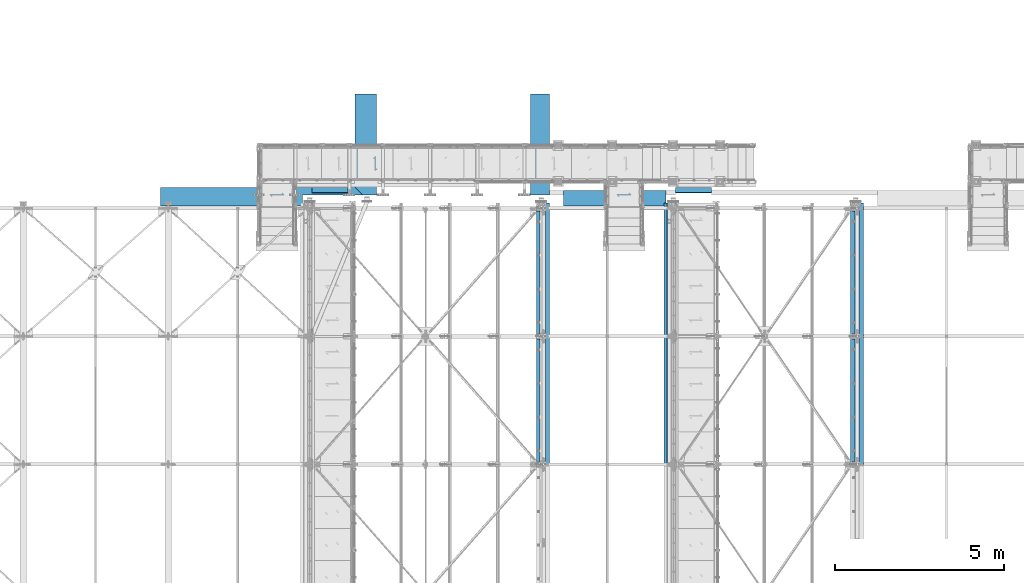
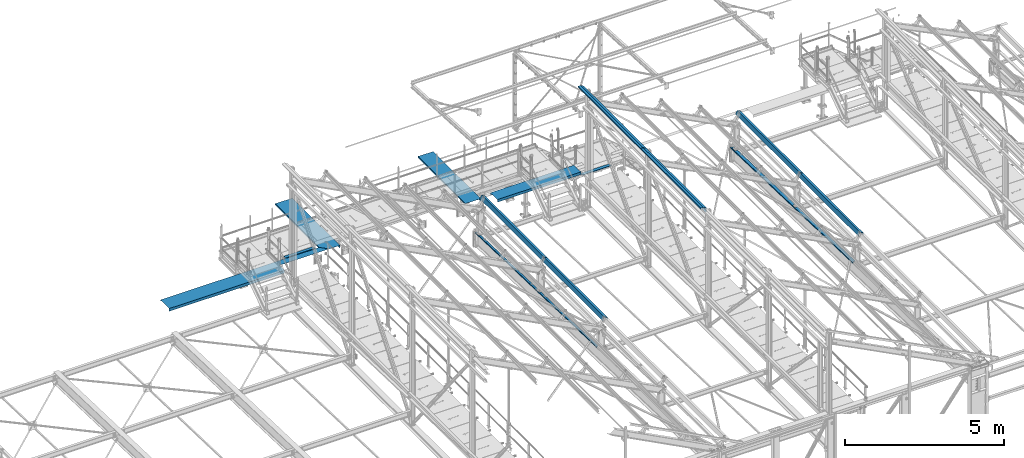
# One storey, part 349 of 496: 16 beams, 16 elements without a shape of their own.
"""IFC2X3 building model written with IfcOpenShell, lengths in millimetres."""

from ifc_helpers import new_model, si_unit, frame, origin_with_axes, place, context, subcontext, project, spatial, faceted_brep, material, type_object, element, aggregate, save


model = new_model("IFC2X3")

# Units and contexts
model_context = context("Model", 3, precision=1e-05, world=origin_with_axes())
body_context = subcontext(model_context, "Body", "Model", "MODEL_VIEW")
ifc_project = project(units=[si_unit("LENGTHUNIT", "METRE", prefix="MILLI"), si_unit("AREAUNIT", "SQUARE_METRE"), si_unit("VOLUMEUNIT", "CUBIC_METRE"), si_unit("MASSUNIT", "GRAM", prefix="KILO"), si_unit("TIMEUNIT", "SECOND"), si_unit("PLANEANGLEUNIT", "RADIAN"), si_unit("SOLIDANGLEUNIT", "STERADIAN"), si_unit("THERMODYNAMICTEMPERATUREUNIT", "DEGREE_CELSIUS"), si_unit("LUMINOUSINTENSITYUNIT", "LUMEN")], contexts=[model_context])

# Site, building, storey
site_placement = place(None, origin_with_axes())
site = spatial("IfcSite", under=ifc_project, at=site_placement, CompositionType="ELEMENT")
building_placement = place(site_placement, origin_with_axes())
building = spatial("IfcBuilding", under=site, at=building_placement, Name="Undefined", CompositionType="ELEMENT")
storey_placement = place(building_placement, origin_with_axes())
storey = spatial("IfcBuildingStorey", under=building, at=storey_placement, Name="Undefined", CompositionType="ELEMENT", Elevation=0.0)

# Assembly, beam
assembly_1_placement = place(storey_placement, origin_with_axes())
assembly_1 = element("IfcElementAssembly", 1, at=assembly_1_placement, inside=storey, AssemblyPlace="NOTDEFINED", PredefinedType="NOTDEFINED")
ifc_material = material(Name="Undefined/S235-E24")
beam_type_1 = type_object("IfcBeamType", PredefinedType="NOTDEFINED")
beam_1_placement = place(assembly_1_placement, frame((13279.0100000575, 15804.7464905488, 8669.96021550788), z_axis=(-1.0, 0.0, 0.0), x_axis=(0.0, 0.707106781186548, -0.707106781186548)))
beam_1 = element("IfcBeam", 2, at=beam_1_placement, type_object=beam_type_1, material=ifc_material, context=body_context, shape_type="Brep", body=[
    faceted_brep([(-9.09494701772928e-13, -0.5, -532.5), (-9.09494701772928e-13, -0.5, 532.5), (0.0, 0.5, 532.5), (0.0, 0.5, -532.5), (14.9999999961674, 0.5, 532.5), (14.9999999961674, 0.5, -532.5), (12.5857864337941, -0.5, -532.5), (12.5857864337941, -0.5, 532.5), (-20.3553390631714, -34.855339059337, 532.5), (-20.3553390631714, -34.855339059337, -532.5), (-20.4043516593701, -33.4901380931624, -532.5), (-20.4043516593701, -33.4901380931624, 532.5), (-136.320853875218, 65.5538265665964, 532.5), (-136.320853875218, 65.5538265665964, -532.5), (-136.369866471417, 66.919027532771, -532.5), (-136.369866471417, 66.919027532771, 532.5), (-150.462992196356, 51.4116882454582, 532.5), (-150.462992196356, 51.4116882454582, -532.5), (-151.170098977543, 52.1187950266467, 532.5), (-151.170098977543, 52.1187950266467, -532.5)], [[[0, 1, 2, 3]], [[3, 2, 4, 5]], [[1, 0, 6, 7]], [[5, 4, 8, 9]], [[7, 6, 10, 11]], [[9, 8, 12, 13]], [[11, 10, 14, 15]], [[13, 12, 16, 17]], [[12, 8, 4, 2, 1, 7, 11, 15, 18, 16]], [[15, 14, 19, 18]], [[14, 10, 6, 0, 3, 5, 9, 13, 17, 19]], [[18, 19, 17, 16]]]),
])
aggregate(assembly_1, [beam_1])

assembly_2_placement = place(storey_placement, origin_with_axes())
assembly_2 = element("IfcElementAssembly", 3, at=assembly_2_placement, inside=storey, AssemblyPlace="NOTDEFINED", PredefinedType="NOTDEFINED")
beam_2_placement = place(assembly_2_placement, frame((24069.0000000574, 15804.7467135916, 8079.96015603329), z_axis=(-1.0, 0.0, 0.0), x_axis=(0.0, 0.707106781186548, -0.707106781186548)))
beam_2 = element("IfcBeam", 4, at=beam_2_placement, type_object=beam_type_1, material=ifc_material, context=body_context, shape_type="Brep", body=[
    faceted_brep([(-9.09494701772928e-13, -0.5, -532.5), (-9.09494701772928e-13, -0.5, 532.5), (0.0, 0.5, 532.5), (0.0, 0.5, -532.5), (14.9999999961674, 0.5, 532.5), (14.9999999961674, 0.5, -532.5), (12.5857864337941, -0.5, -532.5), (12.5857864337941, -0.5, 532.5), (-20.3553390631714, -34.855339059337, 532.5), (-20.3553390631714, -34.855339059337, -532.5), (-20.4043516593701, -33.4901380931624, -532.5), (-20.4043516593701, -33.4901380931624, 532.5), (-136.320853875218, 65.5538265665964, 532.5), (-136.320853875218, 65.5538265665964, -532.5), (-136.369866471417, 66.919027532771, -532.5), (-136.369866471417, 66.919027532771, 532.5), (-150.462992196356, 51.4116882454582, 532.5), (-150.462992196356, 51.4116882454582, -532.5), (-151.170098977543, 52.1187950266467, 532.5), (-151.170098977543, 52.1187950266467, -532.5)], [[[0, 1, 2, 3]], [[3, 2, 4, 5]], [[1, 0, 6, 7]], [[5, 4, 8, 9]], [[7, 6, 10, 11]], [[9, 8, 12, 13]], [[11, 10, 14, 15]], [[13, 12, 16, 17]], [[12, 8, 4, 2, 1, 7, 11, 15, 18, 16]], [[15, 14, 19, 18]], [[14, 10, 6, 0, 3, 5, 9, 13, 17, 19]], [[18, 19, 17, 16]]]),
])
aggregate(assembly_2, [beam_2])

assembly_3_placement = place(storey_placement, origin_with_axes())
assembly_3 = element("IfcElementAssembly", 5, at=assembly_3_placement, inside=storey, AssemblyPlace="NOTDEFINED", PredefinedType="NOTDEFINED")
beam_type_2 = type_object("IfcBeamType", PredefinedType="NOTDEFINED")
beam_3_placement = place(assembly_3_placement, frame((19791.0707772034, 17089.9997612773, 8485.02993144951), z_axis=(0.0, 1.0, 0.0), x_axis=(-0.104503987949868, 0.0, 0.994524467523335)))
beam_3 = element("IfcBeam", 6, at=beam_3_placement, type_object=beam_type_2, material=ifc_material, context=body_context, shape_type="Brep", body=[
    faceted_brep([(6.45741238258779e-11, -0.500000000003638, -1500.0), (6.45741238258779e-11, -0.500000000003638, 1500.0), (-6.82121026329696e-11, 0.5, 1500.0), (-6.82121026329696e-11, 0.5, -1500.0), (14.9999488691874, 0.50000000199725, 1500.0), (14.9999488691874, 0.50000000199725, -1500.0), (15.0523282426693, -0.499999997999112, -1500.0), (15.0523282426693, -0.499999997999112, 1500.0), (104.50745235149, 9.90249056020184, 1500.0), (104.50745235149, 9.90249056020184, -1500.0), (103.635028489763, 8.80534279774656, -1500.0), (103.635028489763, 8.80534279774656, 1500.0), (172.974732576857, -545.986188069808, 1500.0), (172.974732576857, -545.986188069808, -1500.0), (171.857784889847, -545.098036786021, -1500.0), (171.857784889847, -545.098036786021, 1500.0), (123.250123489634, -551.210542755707, 1500.0), (123.250123489634, -551.210542755707, -1500.0), (125.546581443116, -549.963759356357, -1500.0), (125.546581443116, -549.963759356357, 1500.0), (132.690217238004, -539.553558699641, 1500.0), (132.690217238004, -539.553558699641, -1500.0), (133.467348390615, -540.18289737765, 1500.0), (133.467348390615, -540.18289737765, -1500.0)], [[[0, 1, 2, 3]], [[3, 2, 4, 5]], [[1, 0, 6, 7]], [[5, 4, 8, 9]], [[7, 6, 10, 11]], [[9, 8, 12, 13]], [[11, 10, 14, 15]], [[13, 12, 16, 17]], [[15, 14, 18, 19]], [[17, 16, 20, 21]], [[16, 12, 8, 4, 2, 1, 7, 11, 15, 19, 22, 20]], [[19, 18, 23, 22]], [[18, 14, 10, 6, 0, 3, 5, 9, 13, 17, 21, 23]], [[22, 23, 21, 20]]]),
])
aggregate(assembly_3, [beam_3])

assembly_4_placement = place(storey_placement, origin_with_axes())
assembly_4 = element("IfcElementAssembly", 7, at=assembly_4_placement, inside=storey, AssemblyPlace="NOTDEFINED", PredefinedType="NOTDEFINED")
beam_4_placement = place(assembly_4_placement, frame((14661.0707772034, 17089.9997612773, 8485.02993144951), z_axis=(0.0, 1.0, 0.0), x_axis=(-0.104503987949868, 0.0, 0.994524467523335)))
beam_4 = element("IfcBeam", 8, at=beam_4_placement, type_object=beam_type_2, material=ifc_material, context=body_context, shape_type="Brep", body=[
    faceted_brep([(-6.82121026329696e-11, 0.5, -1500.0), (-6.82121026329696e-11, 0.5, 1500.0), (14.9999488691874, 0.50000000199725, 1500.0), (14.9999488691874, 0.50000000199725, -1500.0), (6.45741238258779e-11, -0.500000000003638, -1500.0), (6.45741238258779e-11, -0.500000000003638, 1500.0), (15.0523282426693, -0.499999997999112, -1500.0), (15.0523282426693, -0.499999997999112, 1500.0), (103.633088593667, 8.80513901758604, -1500.0), (103.633088593667, 8.80513901758604, 1500.0), (130.5654026462, -620.827255485461, 1500.0), (180.29001173347, -615.602900799553, 1500.0), (104.50745235149, 9.90249056020184, 1500.0), (179.175070573579, -614.714538698441, 1500.0), (132.861860599676, -619.580472086111, 1500.0), (140.782627547223, -609.799610107335, 1500.0), (140.00549639461, -609.170271429324, 1500.0), (104.50745235149, 9.90249056020184, -1500.0), (153.224504095733, -392.205577123423, -1500.0), (152.229854354479, -392.31009427456, -1500.0), (179.175070573579, -614.714538698441, -1275.99735128642), (132.861860599676, -619.580472086111, -1275.99797658939), (140.782627547223, -609.799610107335, -1284.89753556321), (140.00549639461, -609.170271429324, -1285.60464191098), (130.5654026462, -620.827255485461, -1274.99800853966), (180.29001173347, -615.602900799553, -1274.99733717729)], [[[0, 1, 2, 3]], [[4, 5, 1, 0]], [[5, 4, 6, 7]], [[7, 6, 8, 9]], [[10, 11, 12, 2, 1, 5, 7, 9, 13, 14, 15, 16]], [[3, 2, 12, 17]], [[8, 6, 4, 0, 3, 17, 18, 19]], [[13, 9, 8, 19, 20]], [[14, 13, 20, 21]], [[15, 14, 21, 22]], [[16, 15, 22, 23]], [[10, 16, 23, 24]], [[11, 10, 24, 25]], [[17, 12, 11, 25, 18]], [[24, 23, 22, 21, 20, 19, 18, 25]]]),
])
aggregate(assembly_4, [beam_4])

assembly_5_placement = place(storey_placement, origin_with_axes())
assembly_5 = element("IfcElementAssembly", 9, at=assembly_5_placement, inside=storey, Name="SHED", AssemblyPlace="NOTDEFINED", PredefinedType="NOTDEFINED")
beam_type_3 = type_object("IfcBeamType", PredefinedType="NOTDEFINED")
beam_5_placement = place(assembly_5_placement, frame((28966.3687317403, 9500.00024422104, 8772.7482869049), z_axis=(0.0, 1.0, 0.0), x_axis=(-0.887870604061621, -1.29999898490562e-08, 0.460093241031915)))
beam_5 = element("IfcBeam", 10, at=beam_5_placement, type_object=beam_type_3, material=ifc_material, Name="SHED", context=body_context, shape_type="Brep", body=[
    faceted_brep([(-3.49427864421159e-08, -1.49999999999636, -1895.0), (-3.52956703864038e-08, -1.5, 1895.0), (3.49573383573443e-08, 1.5, 1895.0), (3.53102223016322e-08, 1.5, -1895.0), (47.0000011861484, 1.499998899395, 1895.0), (47.0000011898519, 1.49999889939863, -1895.0), (50.0000011927114, -1.50000117085074, -1895.0), (50.0000011890152, -1.50000117085438, 1895.0), (47.000001059947, 135.500002207569, 1895.00000000012), (47.0000010603762, 135.500002214732, -1894.99999999988), (50.0000010575095, 138.500002217588, -1894.99999999987), (50.0000010570839, 138.500002210421, 1895.00000000013), (-88.1757271770839, 135.5000020808, 1895.00000000025), (-88.1757271818278, 135.500002084245, -1894.99999999975), (-90.0000023299144, 138.50000208251, -1894.99999999975), (-90.0000023251705, 138.500002079061, 1895.00000000025), (-124.143850124739, 66.0900733967574, 1895.00000000026), (-124.143850129109, 66.0900733984818, -1894.99999999974), (-126.807461936929, 67.4703531198502, 1895.00000000026), (-126.807461941291, 67.4703531215746, -1894.99999999974)], [[[0, 1, 2, 3]], [[3, 2, 4, 5]], [[1, 0, 6, 7]], [[5, 4, 8, 9]], [[7, 6, 10, 11]], [[9, 8, 12, 13]], [[11, 10, 14, 15]], [[13, 12, 16, 17]], [[12, 8, 4, 2, 1, 7, 11, 15, 18, 16]], [[15, 14, 19, 18]], [[14, 10, 6, 0, 3, 5, 9, 13, 17, 19]], [[18, 19, 17, 16]]]),
])
aggregate(assembly_5, [beam_5])

assembly_6_placement = place(storey_placement, origin_with_axes())
assembly_6 = element("IfcElementAssembly", 11, at=assembly_6_placement, inside=storey, Name="SHED", AssemblyPlace="NOTDEFINED", PredefinedType="NOTDEFINED")
beam_6_placement = place(assembly_6_placement, frame((19656.0539262703, 9500.00010459345, 8773.41543701596), z_axis=(0.0, 1.0, 0.0), x_axis=(-0.886081824994261, -1.3000000762986e-08, 0.46352885499701)))
beam_6 = element("IfcBeam", 12, at=beam_6_placement, type_object=beam_type_3, material=ifc_material, Name="SHED", context=body_context, shape_type="Brep", body=[
    faceted_brep([(-3.49427864421159e-08, -1.49999999999636, -1895.0), (-3.52956703864038e-08, -1.5, 1895.0), (3.49573383573443e-08, 1.5, 1895.0), (3.53102223016322e-08, 1.5, -1895.0), (47.0000011861484, 1.499998899395, 1895.0), (47.0000011898519, 1.49999889939863, -1895.0), (50.0000011927114, -1.50000117085074, -1895.0), (50.0000011890152, -1.50000117085438, 1895.0), (47.000001059947, 135.500002207569, 1895.00000000012), (47.0000010603762, 135.500002214732, -1894.99999999988), (50.0000010575095, 138.500002217588, -1894.99999999987), (50.0000010570839, 138.500002210421, 1895.00000000013), (-88.1836776470482, 135.500002842484, 1895.0000000002), (-88.1836776506789, 135.500002845067, -1894.9999999998), (-90.0000023299144, 138.50000208251, -1894.99999999975), (-90.0000023251705, 138.500002079061, 1895.00000000025), (-124.424035514965, 66.2228546085316, 1895.00000000021), (-124.424035518201, 66.2228546098777, -1894.99999999979), (-127.082281608209, 67.6134399916555, 1895.00000000021), (-127.082281611441, 67.6134399930015, -1894.99999999979)], [[[0, 1, 2, 3]], [[3, 2, 4, 5]], [[1, 0, 6, 7]], [[5, 4, 8, 9]], [[7, 6, 10, 11]], [[9, 8, 12, 13]], [[11, 10, 14, 15]], [[13, 12, 16, 17]], [[12, 8, 4, 2, 1, 7, 11, 15, 18, 16]], [[15, 14, 19, 18]], [[14, 10, 6, 0, 3, 5, 9, 13, 17, 19]], [[18, 19, 17, 16]]]),
])
aggregate(assembly_6, [beam_6])

assembly_7_placement = place(storey_placement, origin_with_axes())
assembly_7 = element("IfcElementAssembly", 13, at=assembly_7_placement, inside=storey, Name="SHED", AssemblyPlace="NOTDEFINED", PredefinedType="NOTDEFINED")
beam_7_placement = place(assembly_7_placement, frame((23194.99999895, 9500.00015768597, 11825.822934215), z_axis=(0.0, 1.0, 0.0), x_axis=(0.0, 0.0, 1.0)))
beam_7 = element("IfcBeam", 14, at=beam_7_placement, type_object=beam_type_3, material=ifc_material, Name="SHED", context=body_context, shape_type="Brep", body=[
    faceted_brep([(-3.49427864421159e-08, -1.49999999999636, -1895.0), (-3.52956703864038e-08, -1.5, 1895.0), (3.49573383573443e-08, 1.5, 1895.0), (3.53102223016322e-08, 1.5, -1895.0), (47.0000011861484, 1.499998899395, 1895.0), (47.0000011898519, 1.49999889939863, -1895.0), (50.0000011927114, -1.50000117085074, -1895.0), (50.0000011890152, -1.50000117085438, 1895.0), (47.0, 83.4669820349482, 1895.0), (47.0, 83.4669820349482, -1895.0), (50.0, 84.198112487793, -1895.0), (50.0, 84.198112487793, 1895.0), (-16.2373286826551, 205.5, 1895.0), (-16.2373286826551, 205.5, -1895.0), (-14.4130535125732, 208.5, -1895.0), (-14.4130535125732, 208.5, 1895.0), (-151.413055419922, 205.5, 1895.0), (-151.413055419922, 205.5, -1895.0), (-154.413055419922, 208.5, -1895.0), (-154.413055419922, 208.5, 1895.0), (-151.413055419922, 158.5, 1895.0), (-151.413055419922, 158.5, -1895.0), (-154.413055419922, 158.5, 1895.0), (-154.413055419922, 158.5, -1895.0)], [[[0, 1, 2, 3]], [[3, 2, 4, 5]], [[1, 0, 6, 7]], [[5, 4, 8, 9]], [[7, 6, 10, 11]], [[9, 8, 12, 13]], [[11, 10, 14, 15]], [[13, 12, 16, 17]], [[15, 14, 18, 19]], [[17, 16, 20, 21]], [[16, 12, 8, 4, 2, 1, 7, 11, 15, 19, 22, 20]], [[19, 18, 23, 22]], [[18, 14, 10, 6, 0, 3, 5, 9, 13, 17, 21, 23]], [[22, 23, 21, 20]]]),
])
aggregate(assembly_7, [beam_7])

assembly_8_placement = place(storey_placement, origin_with_axes())
assembly_8 = element("IfcElementAssembly", 15, at=assembly_8_placement, inside=storey, AssemblyPlace="NOTDEFINED", PredefinedType="NOTDEFINED")
beam_type_4 = type_object("IfcBeamType", PredefinedType="NOTDEFINED")
beam_8_placement = place(assembly_8_placement, frame((21731.0000035513, 15725.551813145, 8490.0025537872), z_axis=(-1.0, 0.0, 0.0), x_axis=(0.0, -0.104503983004557, 0.994524468042986)))
beam_8 = element("IfcBeam", 16, at=beam_8_placement, type_object=beam_type_4, material=ifc_material, context=body_context, shape_type="Brep", body=[
    faceted_brep([(2.60934029938653e-09, -0.5, -1522.5), (2.60934029938653e-09, -0.5, 1522.5), (-2.6102497940883e-09, 0.5, 1522.5), (-2.6102497940883e-09, 0.5, -1522.5), (9.99994928593878, 0.500000052190444, 1522.5), (9.99994928593878, 0.500000052190444, -1522.5), (10.0523286619564, -0.499999947536708, -1522.5), (10.0523286619564, -0.499999947536708, 1522.5), (99.5074489744575, 9.90249021175259, 1522.5), (99.5074489744575, 9.90249021175259, -1522.5), (98.6392763577842, 8.8057890296368, -1522.5), (98.6392763577842, 8.8057890296368, 1522.5), (156.478023181317, -436.588628127614, 1522.5), (156.478023181317, -436.588628127614, -1522.5), (155.356650238834, -435.700941786734, -1522.5), (155.356650238834, -435.700941786734, 1522.5), (57.0288088006118, -447.037337100774, 1522.5), (57.0288088006118, -447.037337100774, -1522.5), (59.3252667540892, -445.790553701425, -1522.5), (59.3252667540892, -445.790553701425, 1522.5), (66.4689025490106, -435.380353044651, 1522.5), (66.4689025490106, -435.380353044651, -1522.5), (67.2460337016237, -436.009691722662, 1522.5), (67.2460337016237, -436.009691722662, -1522.5)], [[[0, 1, 2, 3]], [[3, 2, 4, 5]], [[1, 0, 6, 7]], [[5, 4, 8, 9]], [[7, 6, 10, 11]], [[9, 8, 12, 13]], [[11, 10, 14, 15]], [[13, 12, 16, 17]], [[15, 14, 18, 19]], [[17, 16, 20, 21]], [[16, 12, 8, 4, 2, 1, 7, 11, 15, 19, 22, 20]], [[19, 18, 23, 22]], [[18, 14, 10, 6, 0, 3, 5, 9, 13, 17, 21, 23]], [[22, 23, 21, 20]]]),
])
aggregate(assembly_8, [beam_8])

assembly_9_placement = place(storey_placement, origin_with_axes())
assembly_9 = element("IfcElementAssembly", 17, at=assembly_9_placement, inside=storey, AssemblyPlace="NOTDEFINED", PredefinedType="NOTDEFINED")
beam_type_5 = type_object("IfcBeamType", PredefinedType="NOTDEFINED")
beam_9_placement = place(assembly_9_placement, frame((11255.0000220992, 15273.9292663484, 8485.02993144988), z_axis=(-1.0, 0.0, 0.0), x_axis=(0.0, 0.104503986960844, 0.994524467627261)))
beam_9 = element("IfcBeam", 18, at=beam_9_placement, type_object=beam_type_5, material=ifc_material, context=body_context, shape_type="Brep", body=[
    faceted_brep([(104.507452360738, -9.90249045622295, -1208.49998630155), (14.9999488691446, -0.499999987074261, -1208.49998630155), (4.29281499236822e-10, -0.5, -1208.49998630155), (-4.3473846744746e-10, 0.499999999998181, -1208.49998630155), (15.0523282416307, 0.500000012969394, -1208.49998630155), (103.635672343446, -8.80541032864312, -1208.49998630155), (142.231865183261, 302.865200793538, -1208.49998630155), (143.226560122237, 302.760678893559, -1208.49998630155), (143.226559864101, 302.760678920684, -2999.99998630155), (142.231863460132, 302.865186878984, -3000.0), (169.765982206049, 525.207728586827, 3000.0), (123.455446477181, 530.073380956279, 3000.0), (123.455446477181, 530.073380956279, -2775.99820668076), (169.765982206049, 525.207728586827, -2775.99758141508), (131.376213434367, 520.292518985494, 3000.0), (131.376213434367, 520.292518985494, -2784.89775735025), (130.599082282382, 519.66318030671, 3000.0), (121.158988522466, 531.320164353345, 3000.0), (121.158988522466, 531.320164353345, -2774.99823956407), (130.599082282382, 519.66318030671, -2785.60486303819), (103.635672343446, -8.80541032864312, 3000.0), (15.0523282416307, 0.500000012969394, 3000.0), (-4.3473846744746e-10, 0.499999999998181, 3000.0), (4.29281499236822e-10, -0.5, 3000.0), (14.9999488691446, -0.499999987074261, 3000.0), (104.507452360738, -9.90249045622295, 3000.0), (170.883597614886, 526.095809716915, 3000.0), (170.883597614886, 526.095809716915, -2774.99756820299)], [[[0, 1, 2, 3, 4, 5, 6, 7]], [[8, 7, 6, 9]], [[10, 11, 12, 13]], [[11, 14, 15, 12]], [[16, 17, 18, 19]], [[14, 16, 19, 15]], [[11, 10, 20, 21, 22, 23, 24, 25, 26, 17, 16, 14]], [[17, 26, 27, 18]], [[13, 12, 15, 19, 18, 27, 8, 9]], [[5, 20, 10, 13, 9, 6]], [[21, 20, 5, 4]], [[22, 21, 4, 3]], [[23, 22, 3, 2]], [[24, 23, 2, 1]], [[25, 24, 1, 0]], [[27, 26, 25, 0, 7, 8]]]),
])
aggregate(assembly_9, [beam_9])

assembly_10_placement = place(storey_placement, origin_with_axes())
assembly_10 = element("IfcElementAssembly", 19, at=assembly_10_placement, inside=storey, Name="POUTRE", AssemblyPlace="NOTDEFINED", PredefinedType="NOTDEFINED")
beam_type_6 = type_object("IfcBeamType", PredefinedType="NOTDEFINED")
beam_10_placement = place(assembly_10_placement, frame((28859.9999999999, 9499.71697919142, 7752.46034983002), z_axis=(0.0, 0.999506556345274, -0.0314108870109058), x_axis=(-1.0, 0.0, 0.0)))
beam_10 = element("IfcBeam", 20, at=beam_10_placement, type_object=beam_type_6, material=ifc_material, Name="POUTRE", context=body_context, shape_type="Brep", body=[
    faceted_brep([(84.9999999979264, 0.999999999923602, 1895.93800542073), (84.9999999999563, 0.999999999923602, 1815.93800543636), (84.9999999999563, -1.00000000007185, 1815.93800543636), (84.9999999979264, -1.00000000007731, 1895.93800542073), (7.27595761418343e-12, 1.00000000000182, 1815.93800543633), (0.0, -0.999999999999091, 1815.93800543633), (137.999999999782, 39.0000003423174, -1895.93800544089), (137.999999999767, 0.999999999872671, -1895.9380054409), (137.999999999796, 0.999999999875399, 1895.93800542073), (137.999999999782, 39.0000003423456, 1895.93800542075), (139.999999999782, 39.0000003423174, -1895.93800544089), (139.999999999782, 39.0000003423456, 1895.93800542075), (139.999999999767, -1.00000000012824, -1895.93800544091), (139.999999999796, -1.00000000012733, 1895.93800542073), (85.0000000000728, -1.00000000007822, -1895.93800544091), (85.0000000000728, 0.999999999920874, -1895.9380054409), (85.0000000000582, -1.00000000007913, -1815.93800540536), (85.0000000000582, 0.999999999921783, -1815.93800540536), (0.0, 1.0, -1815.93800540536), (-7.27595761418343e-12, -1.00000000000091, -1815.93800540536)], [[[0, 1, 2, 3]], [[4, 5, 2, 1]], [[6, 7, 8, 9]], [[10, 6, 9, 11]], [[12, 10, 11, 13]], [[7, 6, 10, 12, 14, 15]], [[15, 14, 16, 17]], [[18, 17, 16, 19]], [[0, 8, 7, 15, 17, 18, 4, 1]], [[13, 11, 9, 8, 0, 3]], [[19, 16, 14, 12, 13, 3, 2, 5]], [[18, 19, 5, 4]]]),
])
aggregate(assembly_10, [beam_10])

assembly_11_placement = place(storey_placement, origin_with_axes())
assembly_11 = element("IfcElementAssembly", 21, at=assembly_11_placement, inside=storey, Name="POUTRE", AssemblyPlace="NOTDEFINED", PredefinedType="NOTDEFINED")
beam_11_placement = place(assembly_11_placement, frame((28859.9999999999, 13351.0192249272, 7631.42783689672), z_axis=(0.0, 0.999506556345274, -0.0314108870109058), x_axis=(-1.0, 0.0, 0.0)))
beam_11 = element("IfcBeam", 22, at=beam_11_placement, type_object=beam_type_6, material=ifc_material, Name="POUTRE", context=body_context, shape_type="Brep", body=[
    faceted_brep([(2.3283064365387e-10, 1.00000000000182, 1764.61043258051), (2.3283064365387e-10, -0.999999999999091, 1764.6104325805), (84.999999999869, -1.00000000000909, 1764.61043258061), (84.999999999869, 0.999999999991815, 1764.61043258061), (85.0000000125365, -1.00000000000909, 1934.61043258061), (85.0000000125365, 0.999999999991815, 1934.61043258061), (2.5465851649642e-10, 1.00000000000182, 1934.61043258061), (2.5465851649642e-10, -0.999999999998181, 1934.61043258061), (138.000000001135, 0.99999999998272, 1999.99999999998), (138.000000000167, 39.0000003432142, 1999.99999999997), (137.999999999724, 39.0000003413616, -1947.26557824108), (137.999999998778, 0.999999999980901, -1947.26557824107), (140.000000000167, 39.0000003432142, 1999.99999999997), (140.000000001135, -1.00000000001728, 1999.99999999998), (139.999999998778, -1.0000000000191, -1947.26557824107), (139.999999999724, 39.0000003413616, -1947.26557824107), (-2.47382558882236e-10, 1.0, -1867.26557823348), (84.9999999999854, 0.999999999989996, -1867.26557823341), (84.9999999999854, -1.00000000001182, -1867.26557823341), (-2.47382558882236e-10, -1.00000000000091, -1867.26557823348), (85.0000000017317, 0.999999999988177, -1947.26557824107), (85.0000000017317, -1.00000000001182, -1947.26557824107), (2.61934474110603e-10, 1.00000000000182, 2000.0), (2.61934474110603e-10, -0.999999999998181, 2000.0)], [[[0, 1, 2, 3]], [[3, 2, 4, 5]], [[6, 5, 4, 7]], [[8, 9, 10, 11]], [[12, 13, 14, 15]], [[16, 17, 18, 19]], [[20, 21, 18, 17]], [[11, 10, 15, 14, 21, 20]], [[9, 12, 15, 10]], [[8, 22, 23, 13, 12, 9]], [[23, 22, 6, 7]], [[2, 1, 19, 18, 21, 14, 13, 23, 7, 4]], [[16, 19, 1, 0]], [[22, 8, 11, 20, 17, 16, 0, 3, 5, 6]]]),
])
aggregate(assembly_11, [beam_11])

assembly_12_placement = place(storey_placement, origin_with_axes())
assembly_12 = element("IfcElementAssembly", 23, at=assembly_12_placement, inside=storey, Name="POUTRE", AssemblyPlace="NOTDEFINED", PredefinedType="NOTDEFINED")
beam_12_placement = place(assembly_12_placement, frame((19509.9999999999, 9499.7169791838, 7752.46034983012), z_axis=(0.0, 0.999506556345274, -0.0314108870109058), x_axis=(-1.0, 0.0, 0.0)))
beam_12 = element("IfcBeam", 24, at=beam_12_placement, type_object=beam_type_6, material=ifc_material, Name="POUTRE", context=body_context, shape_type="Brep", body=[
    faceted_brep([(84.9999999979264, 0.999999999923602, 1895.93800542073), (84.9999999999563, 0.999999999923602, 1815.93800543636), (84.9999999999563, -1.00000000007185, 1815.93800543636), (84.9999999979264, -1.00000000007731, 1895.93800542073), (7.27595761418343e-12, 1.00000000000182, 1815.93800543633), (0.0, -0.999999999999091, 1815.93800543633), (97.9999999997781, 39.0000003423347, -1895.93800544557), (97.9999999997708, 0.999999999877218, -1895.93800544559), (97.9999999997854, 0.999999999877218, 1895.93800542178), (97.9999999997781, 39.0000003423356, 1895.9380054218), (99.9999999997781, 39.0000003423347, -1895.93800544557), (99.9999999997781, 39.0000003423356, 1895.9380054218), (99.9999999997708, -1.00000000012551, -1895.93800544559), (99.9999999997854, -1.0000000001246, 1895.93800542178), (85.0000000000728, -1.00000000007822, -1895.93800544091), (85.0000000000728, 0.999999999920874, -1895.9380054409), (85.0000000000582, -1.00000000007913, -1815.93800540536), (85.0000000000582, 0.999999999921783, -1815.93800540536), (0.0, 1.0, -1815.93800540536), (-7.27595761418343e-12, -1.00000000000091, -1815.93800540536)], [[[0, 1, 2, 3]], [[4, 5, 2, 1]], [[6, 7, 8, 9]], [[10, 6, 9, 11]], [[12, 10, 11, 13]], [[7, 6, 10, 12, 14, 15]], [[15, 14, 16, 17]], [[18, 17, 16, 19]], [[0, 8, 7, 15, 17, 18, 4, 1]], [[13, 11, 9, 8, 0, 3]], [[19, 16, 14, 12, 13, 3, 2, 5]], [[18, 19, 5, 4]]]),
])
aggregate(assembly_12, [beam_12])

assembly_13_placement = place(storey_placement, origin_with_axes())
assembly_13 = element("IfcElementAssembly", 25, at=assembly_13_placement, inside=storey, Name="POUTRE", AssemblyPlace="NOTDEFINED", PredefinedType="NOTDEFINED")
beam_13_placement = place(assembly_13_placement, frame((19509.9999999999, 13351.0192249242, 7631.42783689678), z_axis=(0.0, 0.999506556345274, -0.0314108870109058), x_axis=(-1.0, 0.0, 0.0)))
beam_13 = element("IfcBeam", 26, at=beam_13_placement, type_object=beam_type_6, material=ifc_material, Name="POUTRE", context=body_context, shape_type="Brep", body=[
    faceted_brep([(2.3283064365387e-10, 1.00000000000182, 1764.61043258051), (2.3283064365387e-10, -0.999999999999091, 1764.6104325805), (84.999999999869, -1.00000000000909, 1764.61043258061), (84.999999999869, 0.999999999991815, 1764.61043258061), (85.0000000125365, -1.00000000000909, 1934.61043258061), (85.0000000125365, 0.999999999991815, 1934.61043258061), (2.5465851649642e-10, 1.00000000000182, 1934.61043258061), (2.5465851649642e-10, -0.999999999998181, 1934.61043258061), (98.0000000012442, 0.999999999983629, 1999.99999999998), (98.0000000004002, 39.0000003432151, 1999.99999999997), (97.9999999995016, 39.0000003413625, -1947.26557824232), (97.9999999986794, 0.99999999998181, -1947.26557824232), (100.0000000004, 39.0000003432151, 1999.99999999996), (100.000000001244, -1.00000000001637, 1999.99999999998), (99.9999999986794, -1.0000000000191, -1947.26557824233), (99.9999999995016, 39.0000003413625, -1947.26557824232), (-2.47382558882236e-10, 1.0, -1867.26557823348), (84.9999999999854, 0.999999999989996, -1867.26557823341), (84.9999999999854, -1.00000000001182, -1867.26557823341), (-2.47382558882236e-10, -1.00000000000091, -1867.26557823348), (85.0000000017317, 0.999999999988177, -1947.26557824107), (85.0000000017317, -1.00000000001182, -1947.26557824107), (2.61934474110603e-10, 1.00000000000182, 2000.0), (2.61934474110603e-10, -0.999999999998181, 2000.0)], [[[0, 1, 2, 3]], [[3, 2, 4, 5]], [[6, 5, 4, 7]], [[8, 9, 10, 11]], [[12, 13, 14, 15]], [[16, 17, 18, 19]], [[20, 21, 18, 17]], [[11, 10, 15, 14, 21, 20]], [[9, 12, 15, 10]], [[8, 22, 23, 13, 12, 9]], [[23, 22, 6, 7]], [[2, 1, 19, 18, 21, 14, 13, 23, 7, 4]], [[16, 19, 1, 0]], [[22, 8, 11, 20, 17, 16, 0, 3, 5, 6]]]),
])
aggregate(assembly_13, [beam_13])

assembly_14_placement = place(storey_placement, origin_with_axes())
assembly_14 = element("IfcElementAssembly", 27, at=assembly_14_placement, inside=storey, Name="SHED", AssemblyPlace="NOTDEFINED", PredefinedType="NOTDEFINED")
beam_type_7 = type_object("IfcBeamType", PredefinedType="NOTDEFINED")
beam_14_placement = place(assembly_14_placement, frame((19656.0539262703, 13380.0001045935, 8773.41543701287), z_axis=(0.0, 1.0, 0.0), x_axis=(-0.886081824994261, -1.3000000762986e-08, 0.46352885499701)))
beam_14 = element("IfcBeam", 28, at=beam_14_placement, type_object=beam_type_7, material=ifc_material, Name="SHED", context=body_context, shape_type="Brep", body=[
    faceted_brep([(-4.57293936051428e-09, -1.5, -1975.0), (-2.82670953311026e-09, -1.49999999999636, 1975.0), (4.57293936051428e-09, 1.50000000000364, 1975.0), (2.82307155430317e-09, 1.50000000000364, -1975.0), (46.9999982244844, 1.49999988410855, 1974.99999999998), (46.9999982243717, 1.49999988410491, -1975.00000000002), (49.9999982228783, -1.50000012329474, -1975.00000000002), (49.9999982229929, -1.5000001232911, 1974.99999999998), (46.9999982920745, 135.499998582192, 1975.00000000004), (46.9999982902773, 135.499998584666, -1974.99999999997), (49.9999982917725, 138.499998490119, -1974.99999999997), (49.9999982935697, 138.499998487649, 1975.00000000004), (-88.1836776470518, 135.500002842877, 1975.00000000013), (-88.1836776506552, 135.500002844674, -1974.99999999987), (-90.0000045074175, 138.500002901914, -1974.99999999987), (-90.0000045038087, 138.50000290012, 1975.00000000013), (-124.424035514894, 66.2228546089173, 1975.00000000015), (-124.424035518259, 66.2228546094775, -1974.99999999985), (-127.082281608138, 67.6134399920447, 1975.00000000015), (-127.0822816115, 67.6134399926013, -1974.99999999985)], [[[0, 1, 2, 3]], [[3, 2, 4, 5]], [[1, 0, 6, 7]], [[5, 4, 8, 9]], [[7, 6, 10, 11]], [[9, 8, 12, 13]], [[11, 10, 14, 15]], [[13, 12, 16, 17]], [[12, 8, 4, 2, 1, 7, 11, 15, 18, 16]], [[15, 14, 19, 18]], [[14, 10, 6, 0, 3, 5, 9, 13, 17, 19]], [[18, 19, 17, 16]]]),
])
aggregate(assembly_14, [beam_14])

assembly_15_placement = place(storey_placement, origin_with_axes())
assembly_15 = element("IfcElementAssembly", 29, at=assembly_15_placement, inside=storey, Name="SHED", AssemblyPlace="NOTDEFINED", PredefinedType="NOTDEFINED")
beam_15_placement = place(assembly_15_placement, frame((28966.3687317403, 13380.000244221, 8772.74828689879), z_axis=(0.0, 1.0, 0.0), x_axis=(-0.887870604061621, -1.29999898490562e-08, 0.460093241031915)))
beam_15 = element("IfcBeam", 30, at=beam_15_placement, type_object=beam_type_7, material=ifc_material, Name="SHED", context=body_context, shape_type="Brep", body=[
    faceted_brep([(-4.57293936051428e-09, -1.5, -1975.0), (-2.82670953311026e-09, -1.49999999999636, 1975.0), (4.57293936051428e-09, 1.50000000000364, 1975.0), (2.82307155430317e-09, 1.50000000000364, -1975.0), (46.9999982244844, 1.49999988410855, 1974.99999999998), (46.9999982243717, 1.49999988410491, -1975.00000000002), (49.9999982228783, -1.50000012329474, -1975.00000000002), (49.9999982229929, -1.5000001232911, 1974.99999999998), (46.9999982920745, 135.499998582192, 1975.00000000004), (46.9999982902773, 135.499998584666, -1974.99999999997), (49.9999982917725, 138.499998490119, -1974.99999999997), (49.9999982935697, 138.499998487649, 1975.00000000004), (-88.1757271768438, 135.500002081015, 1975.00000000017), (-88.1757271812858, 135.500002083256, -1974.99999999983), (-90.0000045074175, 138.500002901914, -1974.99999999987), (-90.0000045038087, 138.50000290012, 1975.00000000013), (-124.14385012443, 66.0900733969975, 1975.0000000002), (-124.14385012869, 66.0900733978888, -1974.9999999998), (-126.807461936613, 67.4703531200939, 1975.0000000002), (-126.807461940876, 67.4703531209852, -1974.9999999998)], [[[0, 1, 2, 3]], [[3, 2, 4, 5]], [[1, 0, 6, 7]], [[5, 4, 8, 9]], [[7, 6, 10, 11]], [[9, 8, 12, 13]], [[11, 10, 14, 15]], [[13, 12, 16, 17]], [[12, 8, 4, 2, 1, 7, 11, 15, 18, 16]], [[15, 14, 19, 18]], [[14, 10, 6, 0, 3, 5, 9, 13, 17, 19]], [[18, 19, 17, 16]]]),
])
aggregate(assembly_15, [beam_15])

assembly_16_placement = place(storey_placement, origin_with_axes())
assembly_16 = element("IfcElementAssembly", 31, at=assembly_16_placement, inside=storey, Name="SHED", AssemblyPlace="NOTDEFINED", PredefinedType="NOTDEFINED")
beam_16_placement = place(assembly_16_placement, frame((23194.99999895, 13380.000157686, 11825.8229342119), z_axis=(0.0, 1.0, 0.0), x_axis=(0.0, 0.0, 1.0)))
beam_16 = element("IfcBeam", 32, at=beam_16_placement, type_object=beam_type_7, material=ifc_material, Name="SHED", context=body_context, shape_type="Brep", body=[
    faceted_brep([(-4.57293936051428e-09, -1.5, -1975.0), (-2.82670953311026e-09, -1.49999999999636, 1975.0), (4.57293936051428e-09, 1.50000000000364, 1975.0), (2.82307155430317e-09, 1.50000000000364, -1975.0), (46.9999982244844, 1.49999988410855, 1974.99999999998), (46.9999982243717, 1.49999988410491, -1975.00000000002), (49.9999982228783, -1.50000012329474, -1975.00000000002), (49.9999982229929, -1.5000001232911, 1974.99999999998), (47.0, 83.4669820349482, 1975.0), (47.0, 83.4669820349482, -1975.0), (50.0, 84.198112487793, -1975.0), (50.0, 84.198112487793, 1975.0), (-16.2373286826551, 205.5, 1975.0), (-16.2373286826551, 205.5, -1975.0), (-14.4130535125732, 208.5, -1975.0), (-14.4130535125732, 208.5, 1975.0), (-151.413055419922, 205.5, 1975.0), (-151.413055419922, 205.5, -1975.0), (-154.413055419922, 208.5, -1975.0), (-154.413055419922, 208.5, 1975.0), (-151.413055419922, 158.5, 1975.0), (-151.413055419922, 158.5, -1975.0), (-154.413055419922, 158.5, 1975.0), (-154.413055419922, 158.5, -1975.0)], [[[0, 1, 2, 3]], [[3, 2, 4, 5]], [[1, 0, 6, 7]], [[5, 4, 8, 9]], [[7, 6, 10, 11]], [[9, 8, 12, 13]], [[11, 10, 14, 15]], [[13, 12, 16, 17]], [[15, 14, 18, 19]], [[17, 16, 20, 21]], [[16, 12, 8, 4, 2, 1, 7, 11, 15, 19, 22, 20]], [[19, 18, 23, 22]], [[18, 14, 10, 6, 0, 3, 5, 9, 13, 17, 21, 23]], [[22, 23, 21, 20]]]),
])
aggregate(assembly_16, [beam_16])

save(model, "model.ifc")
